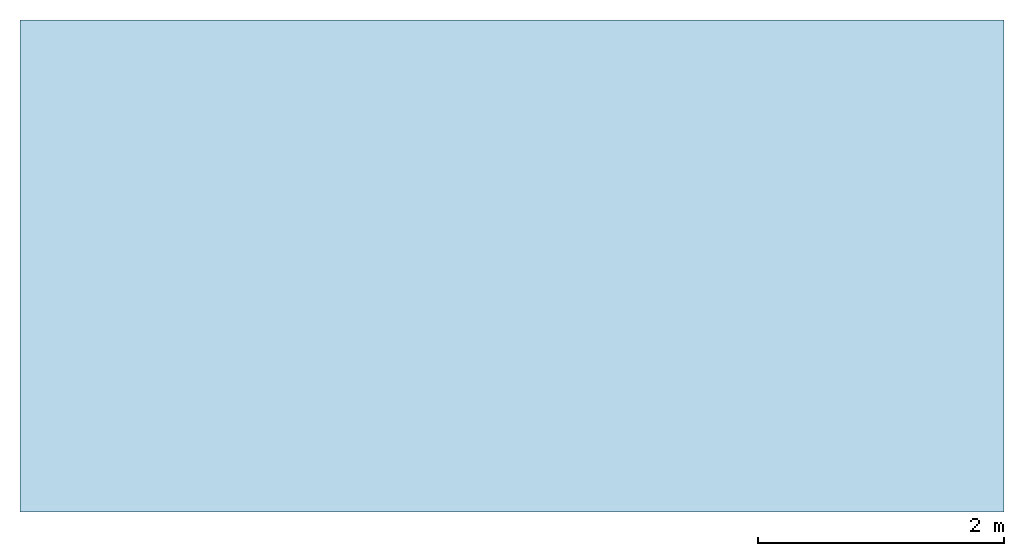
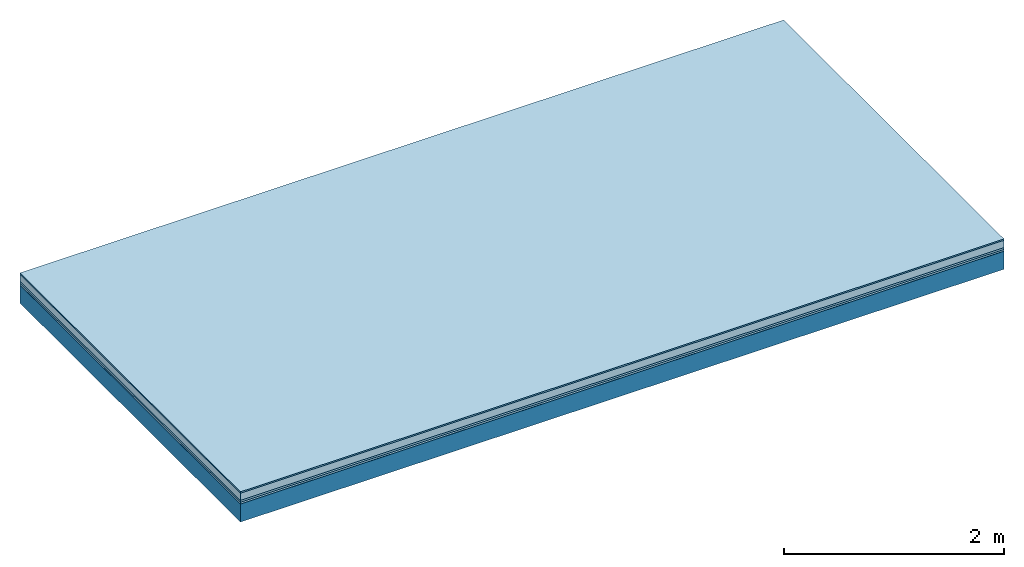
# One storey: 5 plates, 1 member, 1 element without a shape of its own.
"""IFC4 building model written with IfcOpenShell, lengths in metres."""

from ifc_helpers import new_model, si_unit, derived_unit, direction, frame, frame_2d, origin, origin_with_axes, place, context, project, spatial, rectangle, extrude, material, layer, layer_set, type_object, element, aggregate, save


model = new_model("IFC4")

# Units and contexts
plan_context = context("Plan", 3, precision=1e-05, world=origin(), true_north=direction((0.0, 1.0)))
model_context = context("Model", 3, precision=1e-05, world=origin(), true_north=direction((0.0, 1.0)))
ifc_project = project(units=[si_unit("LENGTHUNIT", "METRE"), derived_unit("SOUNDPRESSUREUNIT", [(si_unit("PRESSUREUNIT", "PASCAL", prefix="MICRO"), 0)]), si_unit("ENERGYUNIT", "JOULE", prefix="MEGA"), si_unit("MASSUNIT", "GRAM", prefix="KILO"), derived_unit("THERMALTRANSMITTANCEUNIT", [(si_unit("POWERUNIT", "WATT"), 1), (si_unit("AREAUNIT", "SQUARE_METRE"), -1), (si_unit("THERMODYNAMICTEMPERATUREUNIT", "KELVIN"), -1)]), derived_unit("AREADENSITYUNIT", [(si_unit("MASSUNIT", "GRAM", prefix="KILO"), 1), (si_unit("AREAUNIT", "SQUARE_METRE"), -1)]), derived_unit("USERDEFINED", [(si_unit("ENERGYUNIT", "JOULE", prefix="MEGA"), 1), (si_unit("AREAUNIT", "SQUARE_METRE"), -1)])], contexts=[plan_context, model_context])

# Site, building, storey
site = spatial("IfcSite", under=ifc_project)
building_placement = place(None, origin())
building = spatial("IfcBuilding", under=site, at=building_placement)
storey_placement = place(building_placement, origin())
storey = spatial("IfcBuildingStorey", under=building, at=storey_placement)

# Slab, member, plates
ifc_material_1 = material(Category="11.013")
ifc_layer_1 = layer(ifc_material_1, 0.015, Name="Flooring")
ifc_material_2 = material(Name="Cement screed", Category="04.006")
ifc_layer_2 = layer(ifc_material_2, 0.08, Name="On-material")
ifc_material_3 = material(Name="Wood fiber generic product", Category="10.009")
ifc_layer_3 = layer(ifc_material_3, 0.02, Name="Impact sound insulation")
ifc_material_4 = material()
ifc_layer_4 = layer(ifc_material_4, 0.02, Name="Additional insulation")
ifc_material_5 = material(Name="protection", Category="09.007")
ifc_layer_5 = layer(ifc_material_5, 0.0005, Name="Sub-floor")
ifc_material_6 = material(Name="no composite action")
ifc_layer_6 = layer(ifc_material_6, 0.0, Name="Bond")
ifc_layer_7 = layer(None, 0.2, Name="Supporting structure")
ifc_layer_set = layer_set([ifc_layer_1, ifc_layer_2, ifc_layer_3, ifc_layer_4, ifc_layer_5, ifc_layer_6, ifc_layer_7])
slab_type = type_object("IfcSlabType", Name="A2073", PredefinedType="NOTDEFINED", material=ifc_layer_set)
slab_placement = place(None, frame((0.0, 0.0, 0.0), z_axis=(0.0, 0.0, -1.0), x_axis=(1.0, 0.0, 0.0)))
slab = element("IfcSlab", 1, at=slab_placement, inside=storey, type_object=slab_type, material=ifc_layer_set, Name="Slab #1")
ifc_material_7 = material(Name="Solid timber panel")
member_placement = place(slab_placement, origin())
member = element("IfcMember", 2, at=member_placement, material=ifc_material_7, Name="Supporting structure", context=plan_context, shape_type="SweptSolid", body=[
    extrude(rectangle(XDim=1.0, YDim=0.2, at=frame_2d((0.5, 0.1), x_axis=(1.0, 0.0))), frame((0.0, 4.0, 0.1355), z_axis=(0.0, -1.0, 0.0), x_axis=(1.0, 0.0, 0.0)), (0.0, 0.0, 1.0), 4.0),
    extrude(rectangle(XDim=1.0, YDim=0.2, at=frame_2d((0.5, 0.1), x_axis=(1.0, 0.0))), frame((1.0, 4.0, 0.1355), z_axis=(0.0, -1.0, 0.0), x_axis=(1.0, 0.0, 0.0)), (0.0, 0.0, 1.0), 4.0),
    extrude(rectangle(XDim=1.0, YDim=0.2, at=frame_2d((0.5, 0.1), x_axis=(1.0, 0.0))), frame((2.0, 4.0, 0.1355), z_axis=(0.0, -1.0, 0.0), x_axis=(1.0, 0.0, 0.0)), (0.0, 0.0, 1.0), 4.0),
    extrude(rectangle(XDim=1.0, YDim=0.2, at=frame_2d((0.5, 0.1), x_axis=(1.0, 0.0))), frame((3.0, 4.0, 0.1355), z_axis=(0.0, -1.0, 0.0), x_axis=(1.0, 0.0, 0.0)), (0.0, 0.0, 1.0), 4.0),
    extrude(rectangle(XDim=1.0, YDim=0.2, at=frame_2d((0.5, 0.1), x_axis=(1.0, 0.0))), frame((4.0, 4.0, 0.1355), z_axis=(0.0, -1.0, 0.0), x_axis=(1.0, 0.0, 0.0)), (0.0, 0.0, 1.0), 4.0),
    extrude(rectangle(XDim=1.0, YDim=0.2, at=frame_2d((0.5, 0.1), x_axis=(1.0, 0.0))), frame((5.0, 4.0, 0.1355), z_axis=(0.0, -1.0, 0.0), x_axis=(1.0, 0.0, 0.0)), (0.0, 0.0, 1.0), 4.0),
    extrude(rectangle(XDim=1.0, YDim=0.2, at=frame_2d((0.5, 0.1), x_axis=(1.0, 0.0))), frame((6.0, 4.0, 0.1355), z_axis=(0.0, -1.0, 0.0), x_axis=(1.0, 0.0, 0.0)), (0.0, 0.0, 1.0), 4.0),
    extrude(rectangle(XDim=1.0, YDim=0.2, at=frame_2d((0.5, 0.1), x_axis=(1.0, 0.0))), frame((7.0, 4.0, 0.1355), z_axis=(0.0, -1.0, 0.0), x_axis=(1.0, 0.0, 0.0)), (0.0, 0.0, 1.0), 4.0),
])
plate_1_placement = place(slab_placement, origin())
plate_1 = element("IfcPlate", 3, at=plate_1_placement, material=ifc_material_1, Name="Flooring", context=plan_context, shape_type="SweptSolid", body=[
    extrude(rectangle(XDim=8.0, YDim=4.0, at=frame_2d((4.0, 2.0), x_axis=(1.0, 0.0))), origin_with_axes(), (0.0, 0.0, 1.0), 0.015),
])
plate_2_placement = place(slab_placement, origin())
plate_2 = element("IfcPlate", 4, at=plate_2_placement, material=ifc_material_2, Name="On-material", context=plan_context, shape_type="SweptSolid", body=[
    extrude(rectangle(XDim=8.0, YDim=4.0, at=frame_2d((4.0, 2.0), x_axis=(1.0, 0.0))), frame((0.0, 0.0, 0.015), z_axis=(0.0, 0.0, 1.0), x_axis=(1.0, 0.0, 0.0)), (0.0, 0.0, 1.0), 0.08),
])
plate_3_placement = place(slab_placement, origin())
plate_3 = element("IfcPlate", 5, at=plate_3_placement, material=ifc_material_3, Name="Impact sound insulation", context=plan_context, shape_type="SweptSolid", body=[
    extrude(rectangle(XDim=8.0, YDim=4.0, at=frame_2d((4.0, 2.0), x_axis=(1.0, 0.0))), frame((0.0, 0.0, 0.095), z_axis=(0.0, 0.0, 1.0), x_axis=(1.0, 0.0, 0.0)), (0.0, 0.0, 1.0), 0.02),
])
plate_4_placement = place(slab_placement, origin())
plate_4 = element("IfcPlate", 6, at=plate_4_placement, material=ifc_material_4, Name="Additional insulation", context=plan_context, shape_type="SweptSolid", body=[
    extrude(rectangle(XDim=8.0, YDim=4.0, at=frame_2d((4.0, 2.0), x_axis=(1.0, 0.0))), frame((0.0, 0.0, 0.115), z_axis=(0.0, 0.0, 1.0), x_axis=(1.0, 0.0, 0.0)), (0.0, 0.0, 1.0), 0.02),
])
plate_5_placement = place(slab_placement, origin())
plate_5 = element("IfcPlate", 7, at=plate_5_placement, material=ifc_material_5, Name="Sub-floor", context=plan_context, shape_type="SweptSolid", body=[
    extrude(rectangle(XDim=8.0, YDim=4.0, at=frame_2d((4.0, 2.0), x_axis=(1.0, 0.0))), frame((0.0, 0.0, 0.135), z_axis=(0.0, 0.0, 1.0), x_axis=(1.0, 0.0, 0.0)), (0.0, 0.0, 1.0), 0.0005),
])
aggregate(slab, [plate_1, plate_2, plate_3, plate_4, plate_5, member])

save(model, "model.ifc")
